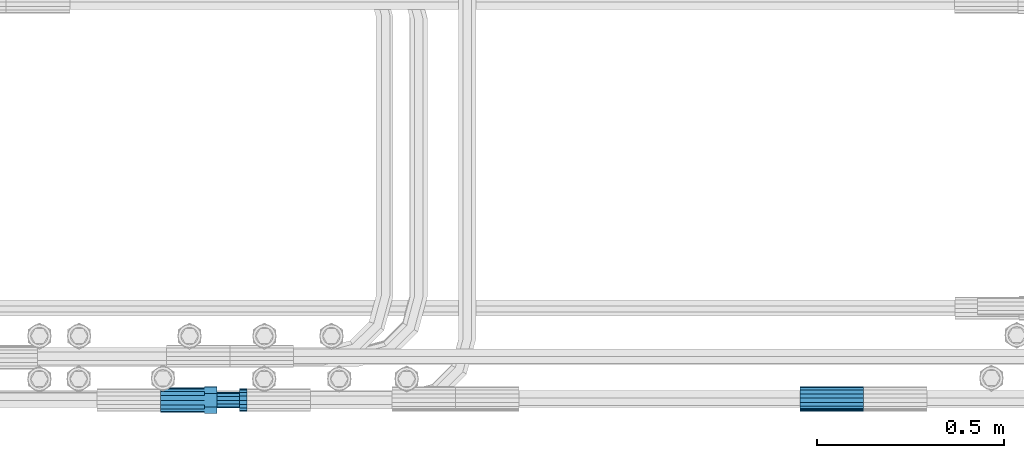
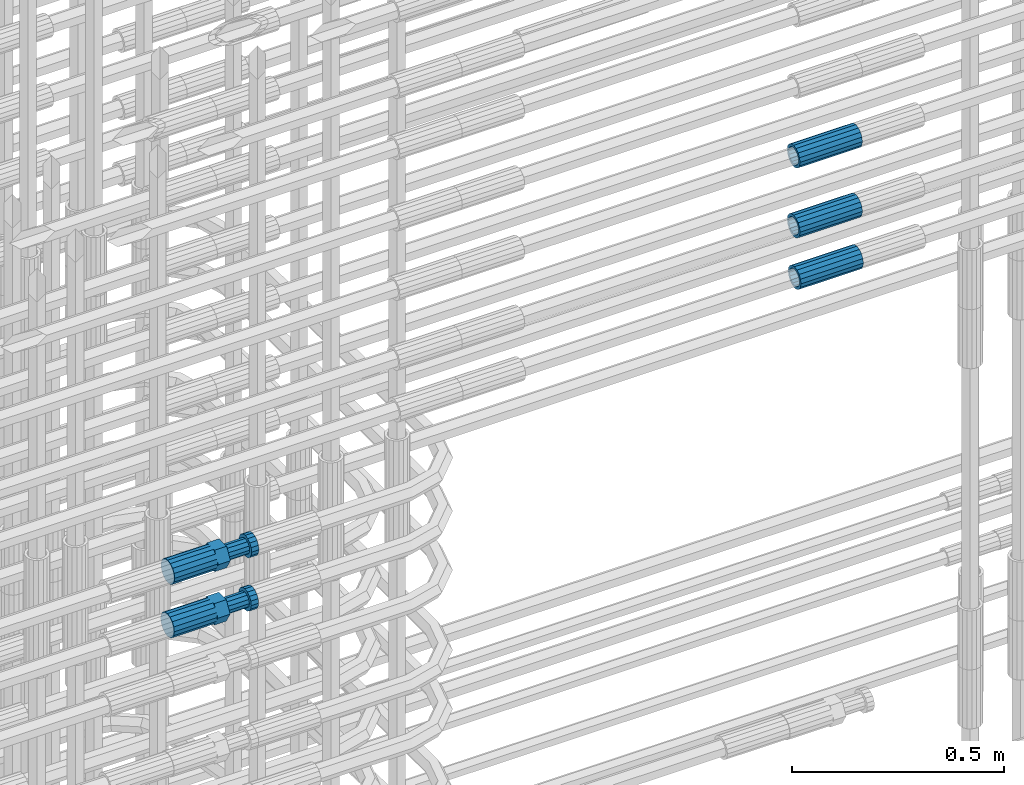
# One storey, part 62 of 119: 5 beams.
"""IFC2X3 building model written with IfcOpenShell, lengths in millimetres."""

from ifc_helpers import new_model, si_unit, frame, origin_with_axes, place, context, subcontext, project, spatial, faceted_brep, material, type_object, element, save


model = new_model("IFC2X3")

# Units and contexts
model_context = context("Model", 3, precision=1e-05, world=origin_with_axes())
body_context = subcontext(model_context, "Body", "Model", "MODEL_VIEW")
ifc_project = project(units=[si_unit("LENGTHUNIT", "METRE", prefix="MILLI"), si_unit("AREAUNIT", "SQUARE_METRE"), si_unit("VOLUMEUNIT", "CUBIC_METRE"), si_unit("MASSUNIT", "GRAM", prefix="KILO"), si_unit("TIMEUNIT", "SECOND"), si_unit("PLANEANGLEUNIT", "RADIAN"), si_unit("SOLIDANGLEUNIT", "STERADIAN"), si_unit("THERMODYNAMICTEMPERATUREUNIT", "DEGREE_CELSIUS"), si_unit("LUMINOUSINTENSITYUNIT", "LUMEN")], contexts=[model_context])

# Site, building, storey
site_placement = place(None, origin_with_axes())
site = spatial("IfcSite", under=ifc_project, at=site_placement, CompositionType="ELEMENT")
building_placement = place(site_placement, origin_with_axes())
building = spatial("IfcBuilding", under=site, at=building_placement, Name="Undefined", CompositionType="ELEMENT")
storey_placement = place(building_placement, origin_with_axes())
storey = spatial("IfcBuildingStorey", under=building, at=storey_placement, Name="Undefined", CompositionType="ELEMENT", Elevation=0.0)

# Beams
ifc_material = material(Name="STEEL/S275")
beam_type_1 = type_object("IfcBeamType", PredefinedType="NOTDEFINED")
beam_1_placement = place(storey_placement, frame((2037555.89023304, 6205098.48994599, 21160.9893980043), z_axis=(0.0, 0.0, 1.0), x_axis=(1.0, 0.0, 0.0)))
element("IfcBeam", 1, at=beam_1_placement, inside=storey, type_object=beam_type_1, material=ifc_material, Name="AG40N", context=body_context, shape_type="Brep", body=[
    faceted_brep([(1.62981450557709e-09, -23.4999999990687, 0.0), (7.45058059692383e-09, -21.7111690142192, 8.99306066057534), (170.000002125278, -21.711168999318, 8.99306066022245), (170.000002127141, -23.4999999844003, -3.66071617463604e-10), (4.65661287307739e-09, -16.6170093587134, 16.6170093578889), (170.000002122484, -16.6170093440451, 16.6170093575288), (1.86264514923096e-09, -8.99306066217832, 21.7111690140277), (170.000002118759, -8.99306064750999, 21.7111690136603), (2.3283064365387e-10, 9.31322574615479e-10, 23.5), (170.000002114102, 1.28056854009628e-08, 23.4999999996485), (-6.51925802230835e-09, 8.99306065868586, 21.7111690140241), (170.00000211224, 8.99306067335419, 21.7111690136639), (-7.45058059692383e-09, 16.6170093561523, 16.6170093578853), (170.000002109446, 16.6170093708206, 16.6170093575324), (-9.31322574615479e-09, 21.711169013055, 8.99306066057534), (170.000002108514, 21.7111690277234, 8.99306066022245), (-1.16415321826935e-09, 23.5000000009313, 0.0), (170.000002108514, 23.5000000144355, -3.66071617463604e-10), (-8.38190317153931e-09, 21.7111690151505, -8.99306066059444), (170.000002110377, 21.7111690300517, -8.9930606609546), (-5.58793544769287e-09, 16.6170093598776, -16.6170093579008), (170.000002113171, 16.6170093745459, -16.6170093582609), (-9.31322574615479e-10, 8.99306066334248, -21.7111690140396), (170.000002115965, 8.99306067801081, -21.7111690143961), (2.3283064365387e-10, 9.31322574615479e-10, -23.5), (170.00000211969, 1.7927959561348e-08, -23.5000000003843), (5.58793544769287e-09, -8.99306065752171, -21.7111690140396), (170.000002123415, -8.99306064285338, -21.7111690143961), (8.38190317153931e-09, -16.6170093549881, -16.6170093579008), (170.000002125278, -16.6170093403198, -16.6170093582646), (9.31322574615479e-09, -21.7111690121237, -8.99306066059444), (170.000002127141, -21.7111689972226, -8.9930606609546), (1.11758708953857e-08, -30.4999999990687, -9.54969436861575e-12), (1.30385160446167e-08, -28.1783257392235, -11.6718446871514), (170.000002129003, -28.1783257243223, -11.6718446875116), (170.000002129935, -30.4999999841675, -3.66071617463604e-10), (1.02445483207703e-08, -21.5667568228673, -21.5667568262129), (170.000002128072, -21.566756808199, -21.5667568265694), (7.45058059692383e-09, -11.6718446831219, -28.1783257416196), (170.000002125278, -11.6718446684536, -28.1783257419834), (3.72529029846191e-09, 3.95812094211578e-09, -30.5000000000277), (170.00000211969, 1.83936208486557e-08, -30.5000000003879), (-9.31322574615479e-10, 11.6718446905725, -28.1783257416232), (170.000002115965, 11.6718447052408, -28.1783257419797), (-6.51925802230835e-09, 21.5667568286881, -21.5667568262093), (170.000002110377, 21.5667568433564, -21.5667568265694), (-9.31322574615479e-09, 28.178325742716, -11.6718446871478), (170.000002108514, 28.1783257573843, -11.6718446875079), (-1.21071934700012e-08, 30.5, -5.91171556152403e-12), (170.000002106652, 30.5000000144355, -3.62433638656512e-10), (-1.21071934700012e-08, 28.1783257401548, 11.6718446871359), (170.00000210572, 28.1783257548232, 11.6718446867794), (-1.02445483207703e-08, 21.5667568240315, 21.5667568261974), (170.000002107583, 21.566756838467, 21.5667568258409), (-7.45058059692383e-09, 11.671844684286, 28.1783257416041), (170.000002110377, 11.6718446989544, 28.178325741244), (-2.79396772384644e-09, -2.56113708019257e-09, 30.5000000000159), (170.000002114102, 1.18743628263474e-08, 30.4999999996558), (1.86264514923096e-09, -11.6718446896411, 28.1783257416114), (170.000002118759, -11.67184467474, 28.178325741244), (7.45058059692383e-09, -21.5667568275239, 21.5667568261974), (170.000002123415, -21.5667568126228, 21.5667568258373), (1.02445483207703e-08, -28.1783257415518, 11.6718446871359), (170.000002127141, -28.1783257271163, 11.6718446867794)], [[[0, 1, 2, 3]], [[1, 4, 5, 2]], [[4, 6, 7, 5]], [[6, 8, 9, 7]], [[8, 10, 11, 9]], [[10, 12, 13, 11]], [[12, 14, 15, 13]], [[14, 16, 17, 15]], [[16, 18, 19, 17]], [[18, 20, 21, 19]], [[20, 22, 23, 21]], [[22, 24, 25, 23]], [[24, 26, 27, 25]], [[26, 28, 29, 27]], [[28, 30, 31, 29]], [[30, 0, 3, 31]], [[32, 33, 34, 35]], [[33, 36, 37, 34]], [[36, 38, 39, 37]], [[38, 40, 41, 39]], [[40, 42, 43, 41]], [[42, 44, 45, 43]], [[44, 46, 47, 45]], [[46, 48, 49, 47]], [[48, 50, 51, 49]], [[50, 52, 53, 51]], [[52, 54, 55, 53]], [[54, 56, 57, 55]], [[56, 58, 59, 57]], [[58, 60, 61, 59]], [[60, 62, 63, 61]], [[62, 32, 35, 63]], [[37, 39, 41, 43, 45, 47, 49, 51, 53, 55, 57, 59, 61, 63, 35, 34], [5, 7, 9, 11, 13, 15, 17, 19, 21, 23, 25, 27, 29, 31, 3, 2]], [[62, 60, 58, 56, 54, 52, 50, 48, 46, 44, 42, 40, 38, 36, 33, 32], [30, 28, 26, 24, 22, 20, 18, 16, 14, 12, 10, 8, 6, 4, 1, 0]]]),
])
beam_2_placement = place(storey_placement, frame((2037555.89023304, 6205102.98994599, 21306.9893980043), z_axis=(0.0, 0.0, 1.0), x_axis=(1.0, 0.0, 0.0)))
element("IfcBeam", 2, at=beam_2_placement, inside=storey, type_object=beam_type_1, material=ifc_material, Name="AG40N", context=body_context, shape_type="Brep", body=[
    faceted_brep([(1.62981450557709e-09, -23.4999999990687, 0.0), (7.45058059692383e-09, -21.7111690142192, 8.99306066057534), (170.000002125278, -21.711168999318, 8.99306066022245), (170.000002127141, -23.4999999844003, -3.66071617463604e-10), (4.65661287307739e-09, -16.6170093587134, 16.6170093578889), (170.000002122484, -16.6170093440451, 16.6170093575288), (1.86264514923096e-09, -8.99306066217832, 21.7111690140277), (170.000002118759, -8.99306064750999, 21.7111690136603), (2.3283064365387e-10, 9.31322574615479e-10, 23.5), (170.000002114102, 1.28056854009628e-08, 23.4999999996485), (-6.51925802230835e-09, 8.99306065868586, 21.7111690140241), (170.00000211224, 8.99306067335419, 21.7111690136639), (-7.45058059692383e-09, 16.6170093561523, 16.6170093578853), (170.000002109446, 16.6170093708206, 16.6170093575324), (-9.31322574615479e-09, 21.711169013055, 8.99306066057534), (170.000002108514, 21.7111690277234, 8.99306066022245), (-1.16415321826935e-09, 23.5000000009313, 0.0), (170.000002108514, 23.5000000144355, -3.66071617463604e-10), (-8.38190317153931e-09, 21.7111690151505, -8.99306066059444), (170.000002110377, 21.7111690300517, -8.9930606609546), (-5.58793544769287e-09, 16.6170093598776, -16.6170093579008), (170.000002113171, 16.6170093745459, -16.6170093582609), (-9.31322574615479e-10, 8.99306066334248, -21.7111690140396), (170.000002115965, 8.99306067801081, -21.7111690143961), (2.3283064365387e-10, 9.31322574615479e-10, -23.5), (170.00000211969, 1.7927959561348e-08, -23.5000000003843), (5.58793544769287e-09, -8.99306065752171, -21.7111690140396), (170.000002123415, -8.99306064285338, -21.7111690143961), (8.38190317153931e-09, -16.6170093549881, -16.6170093579008), (170.000002125278, -16.6170093403198, -16.6170093582646), (9.31322574615479e-09, -21.7111690121237, -8.99306066059444), (170.000002127141, -21.7111689972226, -8.9930606609546), (1.11758708953857e-08, -30.4999999990687, -9.54969436861575e-12), (1.30385160446167e-08, -28.1783257392235, -11.6718446871514), (170.000002129003, -28.1783257243223, -11.6718446875116), (170.000002129935, -30.4999999841675, -3.66071617463604e-10), (1.02445483207703e-08, -21.5667568228673, -21.5667568262129), (170.000002128072, -21.566756808199, -21.5667568265694), (7.45058059692383e-09, -11.6718446831219, -28.1783257416196), (170.000002125278, -11.6718446684536, -28.1783257419834), (3.72529029846191e-09, 3.95812094211578e-09, -30.5000000000277), (170.00000211969, 1.83936208486557e-08, -30.5000000003879), (-9.31322574615479e-10, 11.6718446905725, -28.1783257416232), (170.000002115965, 11.6718447052408, -28.1783257419797), (-6.51925802230835e-09, 21.5667568286881, -21.5667568262093), (170.000002110377, 21.5667568433564, -21.5667568265694), (-9.31322574615479e-09, 28.178325742716, -11.6718446871478), (170.000002108514, 28.1783257573843, -11.6718446875079), (-1.21071934700012e-08, 30.5, -5.91171556152403e-12), (170.000002106652, 30.5000000144355, -3.62433638656512e-10), (-1.21071934700012e-08, 28.1783257401548, 11.6718446871359), (170.00000210572, 28.1783257548232, 11.6718446867794), (-1.02445483207703e-08, 21.5667568240315, 21.5667568261974), (170.000002107583, 21.566756838467, 21.5667568258409), (-7.45058059692383e-09, 11.671844684286, 28.1783257416041), (170.000002110377, 11.6718446989544, 28.178325741244), (-2.79396772384644e-09, -2.56113708019257e-09, 30.5000000000159), (170.000002114102, 1.18743628263474e-08, 30.4999999996558), (1.86264514923096e-09, -11.6718446896411, 28.1783257416114), (170.000002118759, -11.67184467474, 28.178325741244), (7.45058059692383e-09, -21.5667568275239, 21.5667568261974), (170.000002123415, -21.5667568126228, 21.5667568258373), (1.02445483207703e-08, -28.1783257415518, 11.6718446871359), (170.000002127141, -28.1783257271163, 11.6718446867794)], [[[0, 1, 2, 3]], [[1, 4, 5, 2]], [[4, 6, 7, 5]], [[6, 8, 9, 7]], [[8, 10, 11, 9]], [[10, 12, 13, 11]], [[12, 14, 15, 13]], [[14, 16, 17, 15]], [[16, 18, 19, 17]], [[18, 20, 21, 19]], [[20, 22, 23, 21]], [[22, 24, 25, 23]], [[24, 26, 27, 25]], [[26, 28, 29, 27]], [[28, 30, 31, 29]], [[30, 0, 3, 31]], [[32, 33, 34, 35]], [[33, 36, 37, 34]], [[36, 38, 39, 37]], [[38, 40, 41, 39]], [[40, 42, 43, 41]], [[42, 44, 45, 43]], [[44, 46, 47, 45]], [[46, 48, 49, 47]], [[48, 50, 51, 49]], [[50, 52, 53, 51]], [[52, 54, 55, 53]], [[54, 56, 57, 55]], [[56, 58, 59, 57]], [[58, 60, 61, 59]], [[60, 62, 63, 61]], [[62, 32, 35, 63]], [[37, 39, 41, 43, 45, 47, 49, 51, 53, 55, 57, 59, 61, 63, 35, 34], [5, 7, 9, 11, 13, 15, 17, 19, 21, 23, 25, 27, 29, 31, 3, 2]], [[62, 60, 58, 56, 54, 52, 50, 48, 46, 44, 42, 40, 38, 36, 33, 32], [30, 28, 26, 24, 22, 20, 18, 16, 14, 12, 10, 8, 6, 4, 1, 0]]]),
])
beam_3_placement = place(storey_placement, frame((2037555.89023304, 6205103.07994599, 21507.9693980043), z_axis=(0.0, 0.0, 1.0), x_axis=(1.0, 0.0, 0.0)))
element("IfcBeam", 3, at=beam_3_placement, inside=storey, type_object=beam_type_1, material=ifc_material, Name="AG40N", context=body_context, shape_type="Brep", body=[
    faceted_brep([(1.62981450557709e-09, -23.4999999990687, 0.0), (7.45058059692383e-09, -21.7111690142192, 8.99306066057534), (170.000002125278, -21.711168999318, 8.99306066022245), (170.000002127141, -23.4999999844003, -3.66071617463604e-10), (4.65661287307739e-09, -16.6170093587134, 16.6170093578889), (170.000002122484, -16.6170093440451, 16.6170093575288), (1.86264514923096e-09, -8.99306066217832, 21.7111690140277), (170.000002118759, -8.99306064750999, 21.7111690136603), (2.3283064365387e-10, 9.31322574615479e-10, 23.5), (170.000002114102, 1.28056854009628e-08, 23.4999999996485), (-6.51925802230835e-09, 8.99306065868586, 21.7111690140241), (170.00000211224, 8.99306067335419, 21.7111690136639), (-7.45058059692383e-09, 16.6170093561523, 16.6170093578853), (170.000002109446, 16.6170093708206, 16.6170093575324), (-9.31322574615479e-09, 21.711169013055, 8.99306066057534), (170.000002108514, 21.7111690277234, 8.99306066022245), (-1.16415321826935e-09, 23.5000000009313, 0.0), (170.000002108514, 23.5000000144355, -3.66071617463604e-10), (-8.38190317153931e-09, 21.7111690151505, -8.99306066059444), (170.000002110377, 21.7111690300517, -8.9930606609546), (-5.58793544769287e-09, 16.6170093598776, -16.6170093579008), (170.000002113171, 16.6170093745459, -16.6170093582609), (-9.31322574615479e-10, 8.99306066334248, -21.7111690140396), (170.000002115965, 8.99306067801081, -21.7111690143961), (2.3283064365387e-10, 9.31322574615479e-10, -23.5), (170.00000211969, 1.7927959561348e-08, -23.5000000003843), (5.58793544769287e-09, -8.99306065752171, -21.7111690140396), (170.000002123415, -8.99306064285338, -21.7111690143961), (8.38190317153931e-09, -16.6170093549881, -16.6170093579008), (170.000002125278, -16.6170093403198, -16.6170093582646), (9.31322574615479e-09, -21.7111690121237, -8.99306066059444), (170.000002127141, -21.7111689972226, -8.9930606609546), (1.11758708953857e-08, -30.4999999990687, -9.54969436861575e-12), (1.30385160446167e-08, -28.1783257392235, -11.6718446871514), (170.000002129003, -28.1783257243223, -11.6718446875116), (170.000002129935, -30.4999999841675, -3.66071617463604e-10), (1.02445483207703e-08, -21.5667568228673, -21.5667568262129), (170.000002128072, -21.566756808199, -21.5667568265694), (7.45058059692383e-09, -11.6718446831219, -28.1783257416196), (170.000002125278, -11.6718446684536, -28.1783257419834), (3.72529029846191e-09, 3.95812094211578e-09, -30.5000000000277), (170.00000211969, 1.83936208486557e-08, -30.5000000003879), (-9.31322574615479e-10, 11.6718446905725, -28.1783257416232), (170.000002115965, 11.6718447052408, -28.1783257419797), (-6.51925802230835e-09, 21.5667568286881, -21.5667568262093), (170.000002110377, 21.5667568433564, -21.5667568265694), (-9.31322574615479e-09, 28.178325742716, -11.6718446871478), (170.000002108514, 28.1783257573843, -11.6718446875079), (-1.21071934700012e-08, 30.5, -5.91171556152403e-12), (170.000002106652, 30.5000000144355, -3.62433638656512e-10), (-1.21071934700012e-08, 28.1783257401548, 11.6718446871359), (170.00000210572, 28.1783257548232, 11.6718446867794), (-1.02445483207703e-08, 21.5667568240315, 21.5667568261974), (170.000002107583, 21.566756838467, 21.5667568258409), (-7.45058059692383e-09, 11.671844684286, 28.1783257416041), (170.000002110377, 11.6718446989544, 28.178325741244), (-2.79396772384644e-09, -2.56113708019257e-09, 30.5000000000159), (170.000002114102, 1.18743628263474e-08, 30.4999999996558), (1.86264514923096e-09, -11.6718446896411, 28.1783257416114), (170.000002118759, -11.67184467474, 28.178325741244), (7.45058059692383e-09, -21.5667568275239, 21.5667568261974), (170.000002123415, -21.5667568126228, 21.5667568258373), (1.02445483207703e-08, -28.1783257415518, 11.6718446871359), (170.000002127141, -28.1783257271163, 11.6718446867794)], [[[0, 1, 2, 3]], [[1, 4, 5, 2]], [[4, 6, 7, 5]], [[6, 8, 9, 7]], [[8, 10, 11, 9]], [[10, 12, 13, 11]], [[12, 14, 15, 13]], [[14, 16, 17, 15]], [[16, 18, 19, 17]], [[18, 20, 21, 19]], [[20, 22, 23, 21]], [[22, 24, 25, 23]], [[24, 26, 27, 25]], [[26, 28, 29, 27]], [[28, 30, 31, 29]], [[30, 0, 3, 31]], [[32, 33, 34, 35]], [[33, 36, 37, 34]], [[36, 38, 39, 37]], [[38, 40, 41, 39]], [[40, 42, 43, 41]], [[42, 44, 45, 43]], [[44, 46, 47, 45]], [[46, 48, 49, 47]], [[48, 50, 51, 49]], [[50, 52, 53, 51]], [[52, 54, 55, 53]], [[54, 56, 57, 55]], [[56, 58, 59, 57]], [[58, 60, 61, 59]], [[60, 62, 63, 61]], [[62, 32, 35, 63]], [[37, 39, 41, 43, 45, 47, 49, 51, 53, 55, 57, 59, 61, 63, 35, 34], [5, 7, 9, 11, 13, 15, 17, 19, 21, 23, 25, 27, 29, 31, 3, 2]], [[62, 60, 58, 56, 54, 52, 50, 48, 46, 44, 42, 40, 38, 36, 33, 32], [30, 28, 26, 24, 22, 20, 18, 16, 14, 12, 10, 8, 6, 4, 1, 0]]]),
])
beam_type_2 = type_object("IfcBeamType", Name="ROD65", PredefinedType="NOTDEFINED")
beam_4_placement = place(storey_placement, frame((2035848.66023304, 6205098.98994599, 20757.9894151345), z_axis=(0.0, 0.0, 1.0), x_axis=(1.0, 0.0, 0.0)))
element("IfcBeam", 4, at=beam_4_placement, inside=storey, type_object=beam_type_2, material=ifc_material, Name="AGB40", ObjectType="ROD65", context=body_context, shape_type="Brep", body=[
    faceted_brep([(116.999999999069, 17.8249999252148, 30.8738056446964), (116.999999998137, 22.0056957420893, 23.632628078838), (116.999999999069, 12.4372115600854, 30.0260848066173), (116.999999999069, 8.17543111252598, 30.8738056446964), (117.000000000931, -17.8250000746921, 30.8738056446964), (150.200000001118, -17.8250000723638, 30.8738056446964), (150.199999999255, 17.8249999275431, 30.8738056446964), (117.000000000931, -8.17543109622784, 30.8738056446964), (117.000000001863, -22.0056959956419, 23.6326278985034), (117.000000000931, -12.4372115437873, 30.0260848066173), (117.000000001863, -35.6500000746455, -2.18278728425503e-10), (150.200000002049, -35.6500000723172, -2.18278728425503e-10), (117.000000001863, -30.8443149488885, 8.32369080289209), (117.000000001863, -30.8443149488885, -8.32369080355784), (117.000000002794, -32.4999999918509, 0.0), (117.000000000931, -17.8250000746921, -30.873805645133), (150.200000001118, -17.8250000723638, -30.873805645133), (117.000000001863, -22.0056959961075, -23.6326278982269), (117.000000000931, -8.17543109389953, -30.873805645133), (117.000000000931, -12.4372115437873, -30.0260848066173), (116.999999999069, 17.8249999252148, -30.873805645133), (150.199999999255, 17.8249999275431, -30.873805645133), (116.999999999069, 8.17543111019768, -30.873805645133), (116.999999999069, 12.4372115600854, -30.0260848066173), (116.999999998137, 22.005695742555, -23.6326280785652), (116.999999998137, 35.6499999251682, -2.18278728425503e-10), (150.199999998324, 35.6499999277294, -2.18278728425503e-10), (116.999999998137, 30.8443150522653, -8.32369036550881), (116.999999997206, 32.5000000081491, 0.0), (116.999999998137, 30.8443150522653, 8.32369036483942), (1.86264514923096e-09, -22.9809703885112, 22.9809703885621), (1.86264514923096e-09, -30.0260848065373, 12.4372115518672), (117.000000001863, -30.0260847983882, 12.4372115518672), (117.000000001863, -22.9809703803621, 22.9809703885621), (-1.86264514923096e-09, 22.9809703885112, -22.9809703885621), (-1.86264514923096e-09, 30.0260848065373, -12.4372115518672), (116.999999998137, 30.0260848146863, -12.4372115518672), (116.999999998137, 22.9809703966603, -22.9809703885621), (1.86264514923096e-09, -30.0260848065373, -12.4372115518672), (1.86264514923096e-09, -22.9809703885112, -22.9809703885621), (117.000000001863, -22.9809703803621, -22.9809703885621), (117.000000001863, -30.0260847983882, -12.4372115518672), (9.31322574615479e-10, -12.4372115519363, 30.0260848066173), (0.0, 0.0, 32.5), (-9.31322574615479e-10, 12.4372115519363, 30.0260848066173), (-1.86264514923096e-09, 22.9809703885112, 22.9809703885621), (-1.86264514923096e-09, 30.0260848065373, 12.4372115518672), (-2.79396772384644e-09, 32.5, 0.0), (-9.31322574615479e-10, 12.4372115519363, -30.0260848066173), (0.0, 0.0, -32.5), (9.31322574615479e-10, -12.4372115519363, -30.0260848066173), (2.79396772384644e-09, -32.5, 0.0), (116.999999998137, 22.9809703966603, 22.9809703885621), (116.999999998137, 30.0260848146863, 12.4372115518672), (117.0, 8.14907252788544e-09, -32.5), (117.0, 8.14907252788544e-09, 32.5), (150.200000000186, -10.5000000959262, 18.1865334791873), (150.199999999255, -9.59262251853943e-08, 20.9999999997126), (150.199999998324, 10.4999999040738, 18.1865334791873), (150.199999997392, 18.1865333835594, 10.4999999997126), (150.199999997392, 20.9999999040738, -2.87400325760245e-10), (150.199999997392, 18.1865333835594, -10.5000000002874), (150.199999998324, 10.4999999040738, -18.1865334797621), (150.199999999255, -9.59262251853943e-08, -21.0000000002874), (150.200000000186, -10.5000000959262, -18.1865334797621), (150.200000000186, -18.1865335754119, -10.5000000002874), (150.200000001118, -21.0000000959262, -2.87400325760245e-10), (150.200000000186, -18.1865335754119, 10.4999999997126), (210.979999999516, 10.4999999082647, 18.1865334791873), (210.979999999516, -9.17352735996246e-08, 20.9999999997126), (210.979999997653, 18.1865333877504, 10.4999999997126), (210.979999997653, 20.9999999082647, -2.87400325760245e-10), (210.979999997653, 18.1865333877504, -10.5000000002874), (210.979999999516, 10.4999999082647, -18.1865334797621), (210.979999999516, -9.17352735996246e-08, -21.0000000002874), (210.979999999516, -10.5000000917353, -18.1865334797621), (210.980000000447, -18.1865335712209, -10.5000000002874), (210.980000001378, -21.0000000917353, -2.87400325760245e-10), (210.980000000447, -18.1865335712209, 10.4999999997126), (210.979999999516, -10.5000000917353, 18.1865334791873), (211.001368402503, -27.7269939335529, -11.4911163272045), (211.003082515672, -21.2238095656503, -21.2238154190527), (231.002518340945, -21.2131946226582, -21.2132004554769), (231.000804228708, -27.7163789905608, -11.4805013636287), (211.001368415542, -11.4911086384673, -27.7269970399575), (231.000804241747, -11.4804936954752, -27.7163820763781), (210.996487061493, -0.0106066407170147, -30.0106107396168), (230.995922887698, 8.30227509140968e-06, -29.999995776041), (210.98918159306, 11.4698940692469, -27.7269970332745), (230.988617419265, 11.4805090120062, -27.7163820696951), (210.980564201251, 21.2025913291145, -21.2238154067054), (230.980000027455, 21.2132062721066, -21.2132004431296), (210.971946807578, 27.7057702087332, -11.4911163110701), (230.971382633783, 27.7163851517253, -11.4805013474943), (210.964641331695, 29.9893806746695, -0.0106149565435771), (230.9640771579, 29.9999956176616, 7.03221303410828e-09), (210.959759964608, 27.7057637346443, 11.4698863966551), (230.959195790812, 27.7163786776364, 11.4805013602345), (210.958045851439, 21.2025793667417, 21.2025854885032), (230.957481677644, 21.2131943097338, 21.2132004520827), (210.959759951569, 11.4698784395587, 27.705767109408), (230.959195776843, 11.4804933823179, 27.7163820729838), (210.964641305618, -0.0106235581915826, 29.9893808090674), (230.964077131823, -8.61519947648048e-06, 29.9999957726432), (210.971946774051, -11.4911242681555, 27.7057671027251), (230.971382599324, -11.4805093251634, 27.7163820663009), (210.98056416586, -21.2238215280231, 21.2025854761559), (230.979999991134, -21.2132065852638, 21.2132004397354), (210.989181559533, -27.7270004076418, 11.4698863805206), (230.988617384806, -27.7163854646496, 11.4805013441), (210.996487035416, -30.0106108735781, -0.0106149740058754), (230.995922861621, -29.999995930586, -1.04300852399319e-08)], [[[0, 1, 2, 3]], [[4, 5, 6, 0, 3, 7]], [[8, 4, 7, 9]], [[10, 11, 5, 4, 8, 12]], [[13, 10, 12, 14]], [[15, 16, 11, 10, 13, 17]], [[18, 15, 17, 19]], [[20, 21, 16, 15, 18, 22]], [[20, 22, 23, 24]], [[25, 26, 21, 20, 24, 27]], [[25, 27, 28, 29]], [[30, 31, 32, 33]], [[34, 35, 36, 37]], [[38, 39, 40, 41]], [[31, 30, 42, 43, 44, 45, 46, 47, 35, 34, 48, 49, 50, 39, 38, 51]], [[46, 45, 52, 53]], [[28, 47, 46, 53, 29]], [[27, 36, 35, 47, 28]], [[24, 37, 36, 27]], [[23, 48, 34, 37, 24]], [[22, 54, 49, 48, 23]], [[18, 54, 22]], [[19, 50, 49, 54, 18]], [[17, 40, 39, 50, 19]], [[13, 41, 40, 17]], [[14, 51, 38, 41, 13]], [[12, 32, 31, 51, 14]], [[8, 33, 32, 12]], [[9, 42, 30, 33, 8]], [[7, 55, 43, 42, 9]], [[3, 55, 7]], [[2, 44, 43, 55, 3]], [[1, 52, 45, 44, 2]], [[29, 53, 52, 1]], [[0, 6, 26, 25, 29, 1]], [[5, 11, 16, 21, 26, 6], [56, 57, 58, 59, 60, 61, 62, 63, 64, 65, 66, 67]], [[68, 58, 57, 69]], [[70, 59, 58, 68]], [[71, 60, 59, 70]], [[72, 61, 60, 71]], [[73, 62, 61, 72]], [[74, 63, 62, 73]], [[75, 64, 63, 74]], [[76, 65, 64, 75]], [[77, 66, 65, 76]], [[78, 67, 66, 77]], [[79, 56, 67, 78]], [[69, 57, 56, 79]], [[80, 81, 82, 83]], [[81, 84, 85, 82]], [[84, 86, 87, 85]], [[86, 88, 89, 87]], [[88, 90, 91, 89]], [[90, 92, 93, 91]], [[92, 94, 95, 93]], [[94, 96, 97, 95]], [[96, 98, 99, 97]], [[98, 100, 101, 99]], [[100, 102, 103, 101]], [[102, 104, 105, 103]], [[104, 106, 107, 105]], [[106, 108, 109, 107]], [[108, 110, 111, 109]], [[82, 85, 87, 89, 91, 93, 95, 97, 99, 101, 103, 105, 107, 109, 111, 83]], [[110, 80, 83, 111]], [[108, 106, 104, 102, 100, 98, 96, 94, 92, 90, 88, 86, 84, 81, 80, 110], [78, 77, 76, 75, 74, 73, 72, 71, 70, 68, 69, 79]]]),
])
beam_5_placement = place(storey_placement, frame((2035848.66023304, 6205097.47994599, 20912.769415636), z_axis=(0.0, 0.0, 1.0), x_axis=(1.0, 0.0, 0.0)))
element("IfcBeam", 5, at=beam_5_placement, inside=storey, type_object=beam_type_2, material=ifc_material, Name="AGB40", ObjectType="ROD65", context=body_context, shape_type="Brep", body=[
    faceted_brep([(116.999999999069, 17.8249999252148, 30.8738056446964), (116.999999998137, 22.0056957420893, 23.632628078838), (116.999999999069, 12.4372115600854, 30.0260848066173), (116.999999999069, 8.17543111252598, 30.8738056446964), (117.000000000931, -17.8250000746921, 30.8738056446964), (150.200000001118, -17.8250000723638, 30.8738056446964), (150.199999999255, 17.8249999275431, 30.8738056446964), (117.000000000931, -8.17543109622784, 30.8738056446964), (117.000000001863, -22.0056959956419, 23.6326278985034), (117.000000000931, -12.4372115437873, 30.0260848066173), (117.000000001863, -35.6500000746455, -2.18278728425503e-10), (150.200000002049, -35.6500000723172, -2.18278728425503e-10), (117.000000001863, -30.8443149488885, 8.32369080289209), (117.000000001863, -30.8443149488885, -8.32369080355784), (117.000000002794, -32.4999999918509, 0.0), (117.000000000931, -17.8250000746921, -30.873805645133), (150.200000001118, -17.8250000723638, -30.873805645133), (117.000000001863, -22.0056959961075, -23.6326278982269), (117.000000000931, -8.17543109389953, -30.873805645133), (117.000000000931, -12.4372115437873, -30.0260848066173), (116.999999999069, 17.8249999252148, -30.873805645133), (150.199999999255, 17.8249999275431, -30.873805645133), (116.999999999069, 8.17543111019768, -30.873805645133), (116.999999999069, 12.4372115600854, -30.0260848066173), (116.999999998137, 22.005695742555, -23.6326280785652), (116.999999998137, 35.6499999251682, -2.18278728425503e-10), (150.199999998324, 35.6499999277294, -2.18278728425503e-10), (116.999999998137, 30.8443150522653, -8.32369036550881), (116.999999997206, 32.5000000081491, 0.0), (116.999999998137, 30.8443150522653, 8.32369036483942), (1.86264514923096e-09, -22.9809703885112, 22.9809703885621), (1.86264514923096e-09, -30.0260848065373, 12.4372115518672), (117.000000001863, -30.0260847983882, 12.4372115518672), (117.000000001863, -22.9809703803621, 22.9809703885621), (-1.86264514923096e-09, 22.9809703885112, -22.9809703885621), (-1.86264514923096e-09, 30.0260848065373, -12.4372115518672), (116.999999998137, 30.0260848146863, -12.4372115518672), (116.999999998137, 22.9809703966603, -22.9809703885621), (1.86264514923096e-09, -30.0260848065373, -12.4372115518672), (1.86264514923096e-09, -22.9809703885112, -22.9809703885621), (117.000000001863, -22.9809703803621, -22.9809703885621), (117.000000001863, -30.0260847983882, -12.4372115518672), (9.31322574615479e-10, -12.4372115519363, 30.0260848066173), (0.0, 0.0, 32.5), (-9.31322574615479e-10, 12.4372115519363, 30.0260848066173), (-1.86264514923096e-09, 22.9809703885112, 22.9809703885621), (-1.86264514923096e-09, 30.0260848065373, 12.4372115518672), (-2.79396772384644e-09, 32.5, 0.0), (-9.31322574615479e-10, 12.4372115519363, -30.0260848066173), (0.0, 0.0, -32.5), (9.31322574615479e-10, -12.4372115519363, -30.0260848066173), (2.79396772384644e-09, -32.5, 0.0), (116.999999998137, 22.9809703966603, 22.9809703885621), (116.999999998137, 30.0260848146863, 12.4372115518672), (117.0, 8.14907252788544e-09, -32.5), (117.0, 8.14907252788544e-09, 32.5), (150.200000000186, -10.5000000959262, 18.1865334791873), (150.199999999255, -9.59262251853943e-08, 20.9999999997126), (150.199999998324, 10.4999999040738, 18.1865334791873), (150.199999997392, 18.1865333835594, 10.4999999997126), (150.199999997392, 20.9999999040738, -2.87400325760245e-10), (150.199999997392, 18.1865333835594, -10.5000000002874), (150.199999998324, 10.4999999040738, -18.1865334797621), (150.199999999255, -9.59262251853943e-08, -21.0000000002874), (150.200000000186, -10.5000000959262, -18.1865334797621), (150.200000000186, -18.1865335754119, -10.5000000002874), (150.200000001118, -21.0000000959262, -2.87400325760245e-10), (150.200000000186, -18.1865335754119, 10.4999999997126), (210.979999999516, 10.4999999082647, 18.1865334791873), (210.979999999516, -9.17352735996246e-08, 20.9999999997126), (210.979999997653, 18.1865333877504, 10.4999999997126), (210.979999997653, 20.9999999082647, -2.87400325760245e-10), (210.979999997653, 18.1865333877504, -10.5000000002874), (210.979999999516, 10.4999999082647, -18.1865334797621), (210.979999999516, -9.17352735996246e-08, -21.0000000002874), (210.979999999516, -10.5000000917353, -18.1865334797621), (210.980000000447, -18.1865335712209, -10.5000000002874), (210.980000001378, -21.0000000917353, -2.87400325760245e-10), (210.980000000447, -18.1865335712209, 10.4999999997126), (210.979999999516, -10.5000000917353, 18.1865334791873), (211.001368402503, -27.7269939335529, -11.4911163272045), (211.003082515672, -21.2238095656503, -21.2238154190527), (231.002518340945, -21.2131946226582, -21.2132004554769), (231.000804228708, -27.7163789905608, -11.4805013636287), (211.001368415542, -11.4911086384673, -27.7269970399575), (231.000804241747, -11.4804936954752, -27.7163820763781), (210.996487061493, -0.0106066407170147, -30.0106107396168), (230.995922887698, 8.30227509140968e-06, -29.999995776041), (210.98918159306, 11.4698940692469, -27.7269970332745), (230.988617419265, 11.4805090120062, -27.7163820696951), (210.980564201251, 21.2025913291145, -21.2238154067054), (230.980000027455, 21.2132062721066, -21.2132004431296), (210.971946807578, 27.7057702087332, -11.4911163110701), (230.971382633783, 27.7163851517253, -11.4805013474943), (210.964641331695, 29.9893806746695, -0.0106149565435771), (230.9640771579, 29.9999956176616, 7.03221303410828e-09), (210.959759964608, 27.7057637346443, 11.4698863966551), (230.959195790812, 27.7163786776364, 11.4805013602345), (210.958045851439, 21.2025793667417, 21.2025854885032), (230.957481677644, 21.2131943097338, 21.2132004520827), (210.959759951569, 11.4698784395587, 27.705767109408), (230.959195776843, 11.4804933823179, 27.7163820729838), (210.964641305618, -0.0106235581915826, 29.9893808090674), (230.964077131823, -8.61519947648048e-06, 29.9999957726432), (210.971946774051, -11.4911242681555, 27.7057671027251), (230.971382599324, -11.4805093251634, 27.7163820663009), (210.98056416586, -21.2238215280231, 21.2025854761559), (230.979999991134, -21.2132065852638, 21.2132004397354), (210.989181559533, -27.7270004076418, 11.4698863805206), (230.988617384806, -27.7163854646496, 11.4805013441), (210.996487035416, -30.0106108735781, -0.0106149740058754), (230.995922861621, -29.999995930586, -1.04300852399319e-08)], [[[0, 1, 2, 3]], [[4, 5, 6, 0, 3, 7]], [[8, 4, 7, 9]], [[10, 11, 5, 4, 8, 12]], [[13, 10, 12, 14]], [[15, 16, 11, 10, 13, 17]], [[18, 15, 17, 19]], [[20, 21, 16, 15, 18, 22]], [[20, 22, 23, 24]], [[25, 26, 21, 20, 24, 27]], [[25, 27, 28, 29]], [[30, 31, 32, 33]], [[34, 35, 36, 37]], [[38, 39, 40, 41]], [[31, 30, 42, 43, 44, 45, 46, 47, 35, 34, 48, 49, 50, 39, 38, 51]], [[46, 45, 52, 53]], [[28, 47, 46, 53, 29]], [[27, 36, 35, 47, 28]], [[24, 37, 36, 27]], [[23, 48, 34, 37, 24]], [[22, 54, 49, 48, 23]], [[18, 54, 22]], [[19, 50, 49, 54, 18]], [[17, 40, 39, 50, 19]], [[13, 41, 40, 17]], [[14, 51, 38, 41, 13]], [[12, 32, 31, 51, 14]], [[8, 33, 32, 12]], [[9, 42, 30, 33, 8]], [[7, 55, 43, 42, 9]], [[3, 55, 7]], [[2, 44, 43, 55, 3]], [[1, 52, 45, 44, 2]], [[29, 53, 52, 1]], [[0, 6, 26, 25, 29, 1]], [[5, 11, 16, 21, 26, 6], [56, 57, 58, 59, 60, 61, 62, 63, 64, 65, 66, 67]], [[68, 58, 57, 69]], [[70, 59, 58, 68]], [[71, 60, 59, 70]], [[72, 61, 60, 71]], [[73, 62, 61, 72]], [[74, 63, 62, 73]], [[75, 64, 63, 74]], [[76, 65, 64, 75]], [[77, 66, 65, 76]], [[78, 67, 66, 77]], [[79, 56, 67, 78]], [[69, 57, 56, 79]], [[80, 81, 82, 83]], [[81, 84, 85, 82]], [[84, 86, 87, 85]], [[86, 88, 89, 87]], [[88, 90, 91, 89]], [[90, 92, 93, 91]], [[92, 94, 95, 93]], [[94, 96, 97, 95]], [[96, 98, 99, 97]], [[98, 100, 101, 99]], [[100, 102, 103, 101]], [[102, 104, 105, 103]], [[104, 106, 107, 105]], [[106, 108, 109, 107]], [[108, 110, 111, 109]], [[82, 85, 87, 89, 91, 93, 95, 97, 99, 101, 103, 105, 107, 109, 111, 83]], [[110, 80, 83, 111]], [[108, 106, 104, 102, 100, 98, 96, 94, 92, 90, 88, 86, 84, 81, 80, 110], [78, 77, 76, 75, 74, 73, 72, 71, 70, 68, 69, 79]]]),
])

save(model, "model.ifc")
